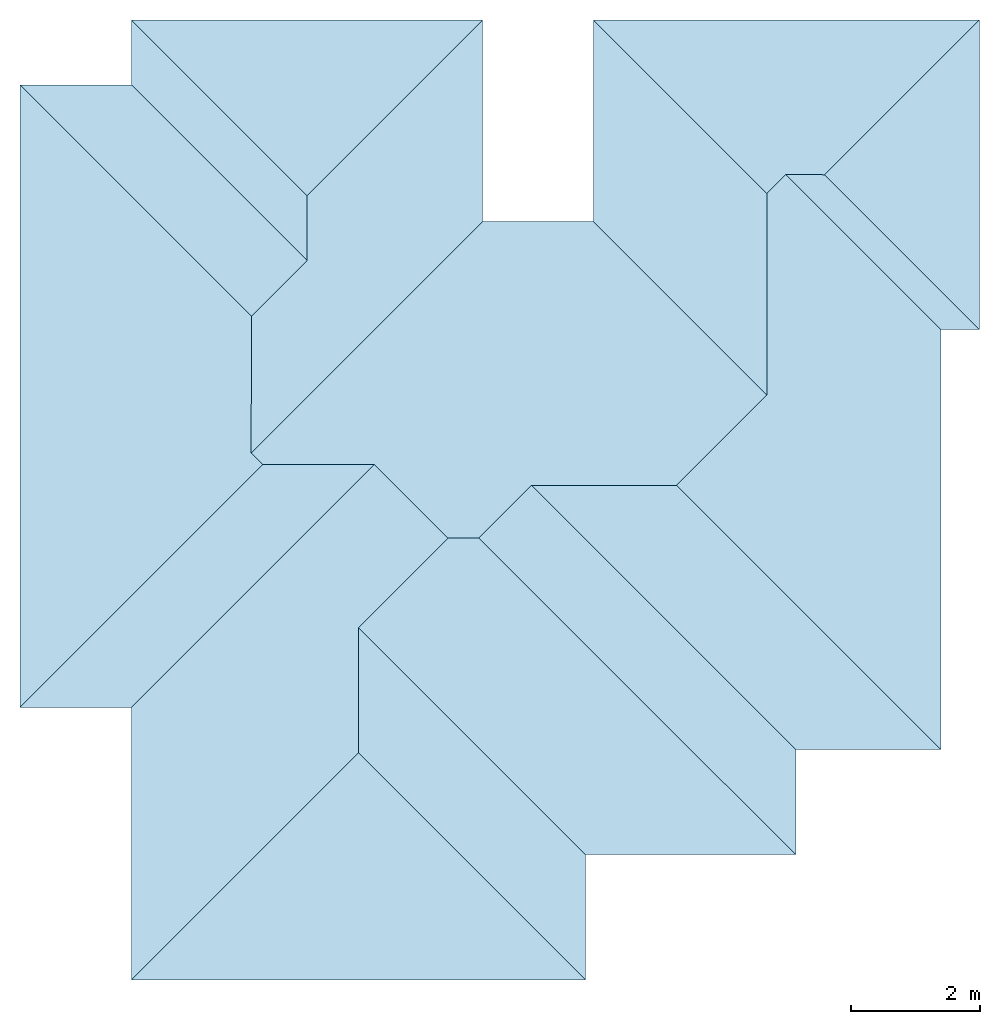
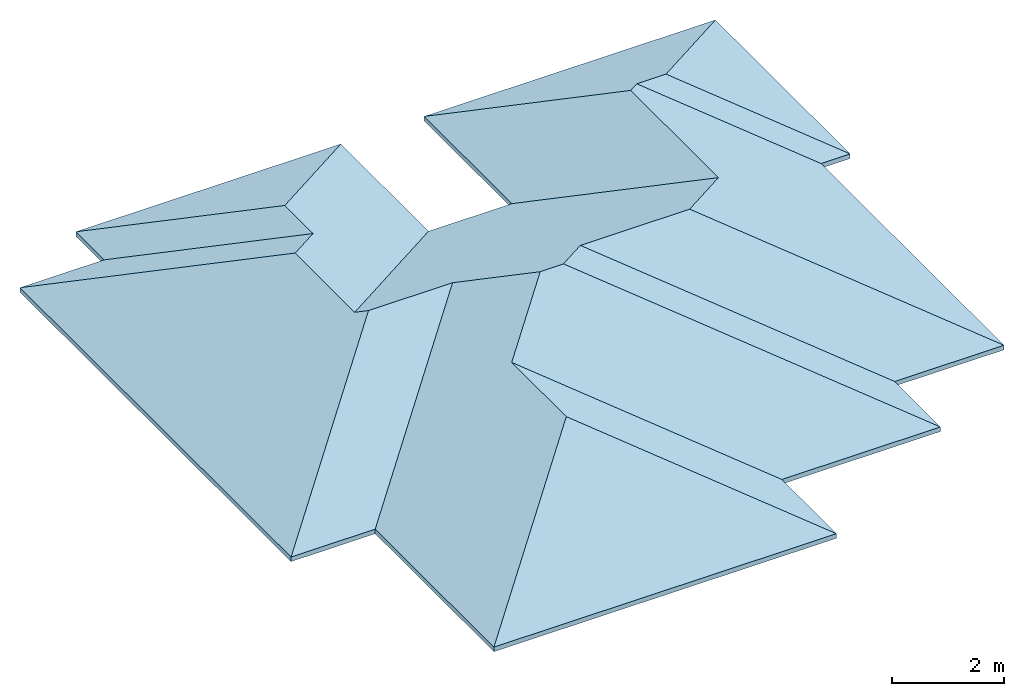
# One storey: 1 roof.
"""IFC4 building model written with IfcOpenShell, lengths in millimetres."""

from ifc_helpers import new_model, entity, si_unit, converted_unit, frame, origin_with_axes, origin_2d_with_axis, place, context, subcontext, project, spatial, polygons, element, save


model = new_model("IFC4")

# Units and contexts
model_context = context("Model", 3, precision=1e-05, world=origin_with_axes())
plan_context = context("Plan", 2, precision=1e-05, world=origin_2d_with_axis())
body_context = subcontext(model_context, "Body", "Model", "MODEL_VIEW")
ifc_project = project(units=[si_unit("LENGTHUNIT", "METRE", prefix="MILLI"), converted_unit("PLANEANGLEUNIT", "degree", entity("IfcReal", 0.0174532925199433), si_unit("PLANEANGLEUNIT", "RADIAN"), dimensions=[0, 0, 0, 0, 0, 0, 0]), si_unit("AREAUNIT", "SQUARE_METRE"), si_unit("VOLUMEUNIT", "CUBIC_METRE")], contexts=[model_context, plan_context])

# Site, building, storey
site_placement = place(None, origin_with_axes())
site = spatial("IfcSite", under=ifc_project, at=site_placement)
building_placement = place(site_placement, origin_with_axes())
building = spatial("IfcBuilding", under=site, at=building_placement, Name="Building")
storey_placement = place(building_placement, frame((0.0, 0.0, 3000.0), z_axis=(0.0, 0.0, 1.0), x_axis=(1.0, 0.0, 0.0)))
storey = spatial("IfcBuildingStorey", under=building, at=storey_placement, Name="ROOF")

# Roof
roof_placement = place(storey_placement, frame((6509.99641418457, 7530.18093109131, 0.0), z_axis=(0.0, 0.0, 1.0), x_axis=(1.0, 0.0, 0.0)))
element("IfcRoof", 1, at=roof_placement, inside=storey, Name="IfcRoof", PredefinedType="HIP_ROOF", context=body_context, shape_type="Tessellation", body=[
    polygons([(-5749.69775390625, 8173.75439453125, 0.0), (-7484.0263671875, 8173.75537109375, 0.0), (-7484.0263671875, -1509.17443847656, 0.0), (-5749.99658203125, -1509.17443847656, 0.0), (-5749.9970703125, -5749.9970703125, 0.0), (1313.26354980469, -5749.9970703125, 0.0), (1313.26379394531, -3800.18017578125, 0.0), (4583.26513671875, -3800.18017578125, 0.0), (4583.26513671875, -2165.677734375, 0.0), (6838.27783203125, -2165.677734375, 0.0), (6838.27783203125, 4368.142578125, 0.0), (7438.2822265625, 4368.142578125, 0.0), (7438.2822265625, 9182.60546875, 0.0), (1433.00378417969, 9182.60546875, 0.0), (1433.00256347656, 6048.14892578125, 0.0), (-286.724487304688, 6048.14892578125, 0.0), (-286.725433349609, 9182.60546875, 0.0), (-5749.69775390625, 9182.60546875, 0.0), (4428.5458984375, 6777.87255859375, 1121.34521484375), (5031.0498046875, 6775.373046875, 1122.51086425781), (4133.14013671875, 6482.46728515625, 1259.09497070312), (4133.1396484375, 3348.01025390625, 1259.09521484375), (-3018.21118164062, 6451.119140625, 1273.71301269531), (-3018.2109375, 5442.26611328125, 1273.71313476562), (-2218.3662109375, -2218.36743164062, 1646.82629394531), (-2218.36596679688, -268.549652099609, 1646.82641601562), (-3887.87451171875, 2446.99755859375, 1676.9130859375), (-3885.375, 4575.10205078125, 1678.07849121094), (-3707.86450195312, 2266.9873046875, 1760.85302734375), (-1973.83447265625, 2266.9873046875, 1760.85302734375), (473.851989746094, 1943.73547363281, 1913.91931152344), (2728.86499023438, 1943.73547363281, 1913.91931152344), (-828.331787109375, 1121.48449707031, 2295.01000976562), (-348.399108886719, 1121.48449707031, 2297.34130859375), (-5749.99658203125, -1509.17443847656, 99.9999923706055), (-5749.9970703125, -5749.9970703125, 99.9999923706055), (-2218.3662109375, -2218.36743164062, 1746.82629394531), (-2218.36596679688, -268.549652099609, 1746.82641601562), (-828.331787109375, 1121.48449707031, 2395.009765625), (-1973.83447265625, 2266.9873046875, 1860.85302734375), (-7484.0263671875, 8173.75537109375, 99.9999923706055), (-7484.0263671875, -1509.17443847656, 99.9999923706055), (-3707.86450195312, 2266.9873046875, 1860.85302734375), (-3887.87451171875, 2446.99755859375, 1776.9130859375), (-3885.375, 4575.10205078125, 1778.07861328125), (7438.2822265625, 4368.142578125, 99.9999923706055), (7438.2822265625, 9182.60546875, 99.9999923706055), (5031.0498046875, 6775.373046875, 1222.51086425781), (-5749.69775390625, 9182.60546875, 99.9999923706055), (-5749.69775390625, 8173.75439453125, 99.9999923706055), (-3018.2109375, 5442.26611328125, 1373.71313476562), (-3018.21118164062, 6451.119140625, 1373.71301269531), (6838.27783203125, -2165.677734375, 99.9999923706055), (6838.27783203125, 4368.142578125, 99.9999923706055), (4428.5458984375, 6777.87255859375, 1221.34521484375), (4133.14013671875, 6482.46728515625, 1359.09497070312), (4133.1396484375, 3348.01025390625, 1359.09521484375), (2728.86499023438, 1943.73547363281, 2013.91918945312), (4583.26513671875, -2165.677734375, 99.9999923706055), (473.851989746094, 1943.73547363281, 2013.91918945312), (1433.00256347656, 6048.14892578125, 99.9999923706055), (-286.724487304688, 6048.14892578125, 99.9999923706055), (-348.399108886719, 1121.48449707031, 2397.34106445312), (4583.26513671875, -3800.18017578125, 99.9999923706055), (-286.725433349609, 9182.60546875, 99.9999923706055), (1433.00378417969, 9182.60546875, 99.9999923706055), (1313.26354980469, -5749.9970703125, 99.9999923706055), (1313.26379394531, -3800.18017578125, 99.9999923706055)], [[[4, 30, 33, 26, 25, 5]], [[2, 28, 27, 29, 3]], [[12, 20, 13]], [[18, 23, 24, 1]], [[21, 19, 11]], [[9, 31, 32, 10]], [[31, 30, 16]], [[11, 20, 12]], [[34, 9, 8]], [[24, 23, 16]], [[13, 20, 19, 21, 14]], [[3, 29, 30, 4]], [[6, 25, 26, 7]], [[5, 25, 6]], [[1, 24, 28, 2]], [[17, 23, 18]], [[26, 33, 34]], [[14, 21, 22, 15]], [[35, 36, 37, 38, 39, 40]], [[41, 42, 43, 44, 45]], [[46, 47, 48]], [[49, 50, 51, 52]], [[54, 56, 57]], [[59, 53, 58, 60]], [[62, 40, 60]], [[54, 48, 55]], [[59, 63, 64]], [[51, 45, 44]], [[47, 66, 56, 55, 48]], [[42, 35, 40, 43]], [[67, 68, 38, 37]], [[36, 67, 37]], [[50, 41, 45, 51]], [[65, 49, 52]], [[38, 63, 39]], [[66, 61, 57, 56]], [[17, 18, 49, 65]], [[10, 11, 54, 53]], [[7, 8, 64, 68]], [[12, 13, 47, 46]], [[3, 4, 35, 42]], [[14, 15, 61, 66]], [[15, 16, 62, 61]], [[8, 9, 59, 64]], [[6, 7, 68, 67]], [[2, 3, 42, 41]], [[16, 17, 65, 62]], [[18, 1, 50, 49]], [[4, 5, 36, 35]], [[5, 6, 67, 36]], [[1, 2, 41, 50]], [[9, 10, 53, 59]], [[13, 14, 66, 47]], [[11, 12, 46, 54]], [[11, 10, 22]], [[10, 32, 22]], [[22, 21, 11]], [[16, 15, 31]], [[15, 22, 32]], [[31, 15, 32]], [[31, 34, 33]], [[30, 29, 27]], [[31, 33, 30]], [[30, 27, 16]], [[11, 19, 20]], [[34, 31, 9]], [[17, 16, 23]], [[16, 27, 24]], [[27, 28, 24]], [[8, 7, 34]], [[7, 26, 34]], [[58, 53, 57]], [[53, 54, 57]], [[54, 55, 56]], [[57, 61, 58]], [[61, 62, 60]], [[58, 61, 60]], [[62, 44, 40]], [[44, 43, 40]], [[40, 39, 60]], [[39, 63, 60]], [[54, 46, 48]], [[59, 60, 63]], [[44, 62, 51]], [[62, 65, 52]], [[51, 62, 52]], [[38, 68, 63]], [[68, 64, 63]]], closed=True),
])

save(model, "model.ifc")
